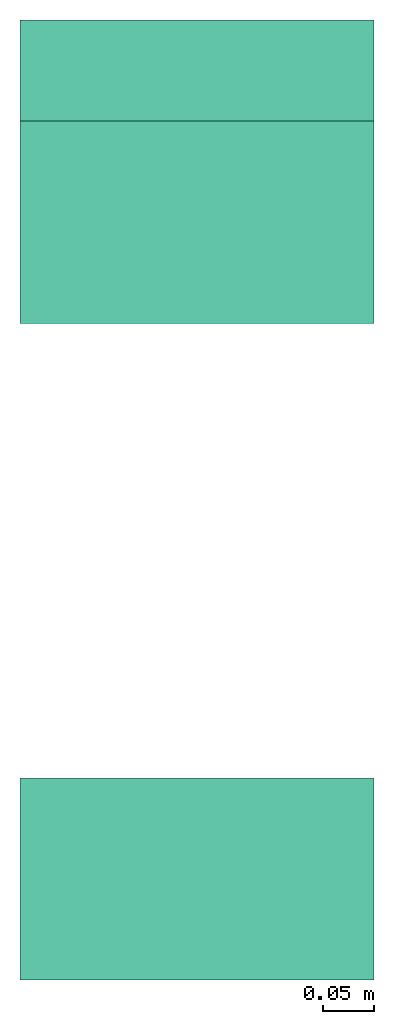
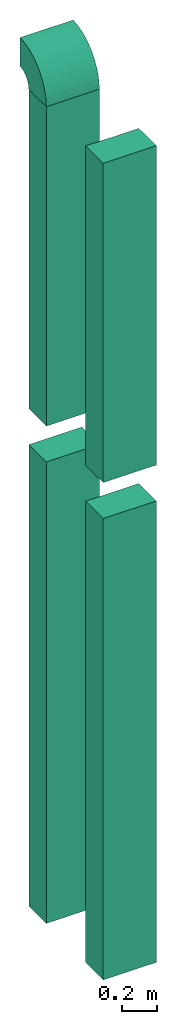
# One storey: 4 flow segments, 1 flow fitting.
"""IFC2X3 building model written with IfcOpenShell, lengths in millimetres."""

from ifc_helpers import new_model, entity, si_unit, converted_unit, derived_unit, direction, frame, frame_2d, origin, place, context, subcontext, project, spatial, polyline, circle_curve, parameter, trimmed, segment, composite_curve, rectangle, outline, extrude, source, transform, mapped, material, type_object, type_shapes, element, save


model = new_model("IFC2X3")

# Units and contexts
model_context = context("Model", 3, precision=0.01, world=origin(), true_north=direction((6.12303176911189e-17, 1.0)))
body_context = subcontext(model_context, "Body", "Model", "MODEL_VIEW")
ifc_project = project(units=[si_unit("LENGTHUNIT", "METRE", prefix="MILLI"), si_unit("AREAUNIT", "SQUARE_METRE"), si_unit("VOLUMEUNIT", "CUBIC_METRE"), converted_unit("PLANEANGLEUNIT", "DEGREE", entity("IfcRatioMeasure", 0.0174532925199433), si_unit("PLANEANGLEUNIT", "RADIAN"), dimensions=[0, 0, 0, 0, 0, 0, 0]), si_unit("MASSUNIT", "GRAM", prefix="KILO"), derived_unit("MASSDENSITYUNIT", [(si_unit("MASSUNIT", "GRAM", prefix="KILO"), 1), (si_unit("LENGTHUNIT", "METRE"), -3)]), derived_unit("MOMENTOFINERTIAUNIT", [(si_unit("LENGTHUNIT", "METRE"), 4)]), si_unit("TIMEUNIT", "SECOND"), si_unit("FREQUENCYUNIT", "HERTZ"), si_unit("THERMODYNAMICTEMPERATUREUNIT", "DEGREE_CELSIUS"), derived_unit("THERMALTRANSMITTANCEUNIT", [(si_unit("MASSUNIT", "GRAM", prefix="KILO"), 1), (si_unit("THERMODYNAMICTEMPERATUREUNIT", "KELVIN"), -1), (si_unit("TIMEUNIT", "SECOND"), -3)]), derived_unit("VOLUMETRICFLOWRATEUNIT", [(si_unit("LENGTHUNIT", "METRE"), 3), (si_unit("TIMEUNIT", "SECOND"), -1)]), si_unit("ELECTRICCURRENTUNIT", "AMPERE"), si_unit("ELECTRICVOLTAGEUNIT", "VOLT"), si_unit("POWERUNIT", "WATT"), si_unit("FORCEUNIT", "NEWTON", prefix="KILO"), si_unit("ILLUMINANCEUNIT", "LUX"), si_unit("LUMINOUSFLUXUNIT", "LUMEN"), si_unit("LUMINOUSINTENSITYUNIT", "CANDELA"), derived_unit("USERDEFINED", [(si_unit("MASSUNIT", "GRAM", prefix="KILO"), -1), (si_unit("LENGTHUNIT", "METRE"), -2), (si_unit("TIMEUNIT", "SECOND"), 3), (si_unit("LUMINOUSFLUXUNIT", "LUMEN"), 1)]), derived_unit("LINEARVELOCITYUNIT", [(si_unit("LENGTHUNIT", "METRE"), 1), (si_unit("TIMEUNIT", "SECOND"), -1)]), si_unit("PRESSUREUNIT", "PASCAL"), derived_unit("USERDEFINED", [(si_unit("LENGTHUNIT", "METRE"), -2), (si_unit("MASSUNIT", "GRAM", prefix="KILO"), 1), (si_unit("TIMEUNIT", "SECOND"), -2)]), derived_unit("LINEARFORCEUNIT", [(si_unit("MASSUNIT", "GRAM", prefix="KILO"), 1), (si_unit("LENGTHUNIT", "METRE"), 1), (si_unit("TIMEUNIT", "SECOND"), -2), (si_unit("LENGTHUNIT", "METRE"), -1)]), derived_unit("PLANARFORCEUNIT", [(si_unit("MASSUNIT", "GRAM", prefix="KILO"), 1), (si_unit("LENGTHUNIT", "METRE"), 1), (si_unit("TIMEUNIT", "SECOND"), -2), (si_unit("LENGTHUNIT", "METRE"), -2)])], contexts=[model_context])

# Site, building, storey
site_placement = place(None, origin())
site = spatial("IfcSite", under=ifc_project, at=site_placement, CompositionType="ELEMENT")
building_placement = place(site_placement, origin())
building = spatial("IfcBuilding", under=site, at=building_placement, CompositionType="ELEMENT")
storey_placement = place(building_placement, frame((0.0, 0.0, 4000.0)))
storey = spatial("IfcBuildingStorey", under=building, at=storey_placement, Name="01 Level", CompositionType="ELEMENT", Elevation=4000.0)

# Flow segments
ifc_material = material()
duct_segment_type = type_object("IfcDuctSegmentType", Name="Rectangular Duct:Air", PredefinedType="NOTDEFINED", material=ifc_material)
flow_segment_1_placement = place(storey_placement, origin())
element("IfcFlowSegment", 1, at=flow_segment_1_placement, inside=storey, type_object=duct_segment_type, Name="Rectangular Duct:Air", ObjectType="Rectangular Duct:Air", context=body_context, shape_type="SweptSolid", body=[
    extrude(rectangle(XDim=349.999999999998, YDim=199.999999999998, at=frame_2d((0.0, -4.33431068813661e-12), x_axis=(1.0, 0.0))), frame((24630.6615179764, -69156.0352293172, 11125.0)), (0.0, 0.0, 1.0), 2225.0),
])
flow_segment_2_placement = place(storey_placement, origin())
element("IfcFlowSegment", 2, at=flow_segment_2_placement, inside=storey, type_object=duct_segment_type, Name="Rectangular Duct:Air", ObjectType="Rectangular Duct:Air", context=body_context, shape_type="SweptSolid", body=[
    extrude(rectangle(XDim=200.000000000007, YDim=349.999999999998, at=frame_2d((-4.33431068813661e-12, 0.0), x_axis=(1.0, 0.0))), frame((24630.6615179764, -68506.4439409627, 11125.0), z_axis=(0.0, 0.0, 1.0), x_axis=(0.0, -1.0, 0.0)), (0.0, 0.0, 1.0), 2225.0),
])
flow_segment_3_placement = place(storey_placement, origin())
element("IfcFlowSegment", 3, at=flow_segment_3_placement, inside=storey, type_object=duct_segment_type, Name="Rectangular Duct:Air", ObjectType="Rectangular Duct:Air", context=body_context, shape_type="SweptSolid", body=[
    extrude(rectangle(XDim=200.000000000007, YDim=349.999999999998, at=frame_2d((-4.33431068813661e-12, 0.0), x_axis=(1.0, 0.0))), frame((24630.6615179764, -68506.4439409627, 7660.0), z_axis=(0.0, 0.0, 1.0), x_axis=(0.0, -1.0, 0.0)), (0.0, 0.0, 1.0), 3215.0),
])
flow_segment_4_placement = place(storey_placement, origin())
element("IfcFlowSegment", 4, at=flow_segment_4_placement, inside=storey, type_object=duct_segment_type, Name="Rectangular Duct:Air", ObjectType="Rectangular Duct:Air", context=body_context, shape_type="SweptSolid", body=[
    extrude(rectangle(XDim=200.000000000007, YDim=349.999999999998, at=frame_2d((-4.33431068813661e-12, 0.0), x_axis=(1.0, 0.0))), frame((24630.6615179764, -69156.0352293172, 7660.0), z_axis=(0.0, 0.0, 1.0), x_axis=(0.0, 1.0, 0.0)), (0.0, 0.0, 1.0), 3215.0),
])

# Flow fitting
duct_fitting_type = type_object("IfcDuctFittingType", Name="elbow1_001:Air_Elbow_Rect", PredefinedType="NOTDEFINED")
shared_shape = source(origin(), body_context, "Body", "SweptSolid", [
    extrude(outline(composite_curve([segment(polyline([(-200.0, -100.0), (0.0, -100.0)]), True, "CONTINUOUS"), segment(trimmed(circle_curve(frame_2d((100.0, -100.0), x_axis=(0.0, 1.0)), 100.0), [parameter(0.0)], [parameter(90.0000000000001)], True, "PARAMETER"), False, "CONTINUOUS"), segment(polyline([(100.0, 0.0), (100.0, 200.0)]), True, "CONTINUOUS"), segment(trimmed(circle_curve(frame_2d((100.0, -100.0), x_axis=(0.0, 1.0)), 300.0), [parameter(0.0)], [parameter(90.0000000000001)], True, "PARAMETER"), True, "CONTINUOUS")], self_intersect=False)), frame((-100.0, 100.0, -175.0), z_axis=(0.0, 0.0, 1.0), x_axis=(-1.0, 0.0, 0.0)), (0.0, 0.0, 1.0), 350.0),
])
type_shapes(duct_fitting_type, [shared_shape])
flow_fitting_placement = place(storey_placement, frame((24630.6615179764, -68506.4439409627, 13550.0), z_axis=(-1.0, 0.0, 0.0), x_axis=(0.0, 0.0, 1.0)))
element("IfcFlowFitting", 5, at=flow_fitting_placement, inside=storey, type_object=duct_fitting_type, Name="elbow1_001:Air_Elbow_Rect", ObjectType="elbow1_001:Air_Elbow_Rect", context=body_context, shape_type="MappedRepresentation", body=[
    mapped(shared_shape, transform((0.0, 0.0, 0.0), scale=1.0)),
])

save(model, "model.ifc")
